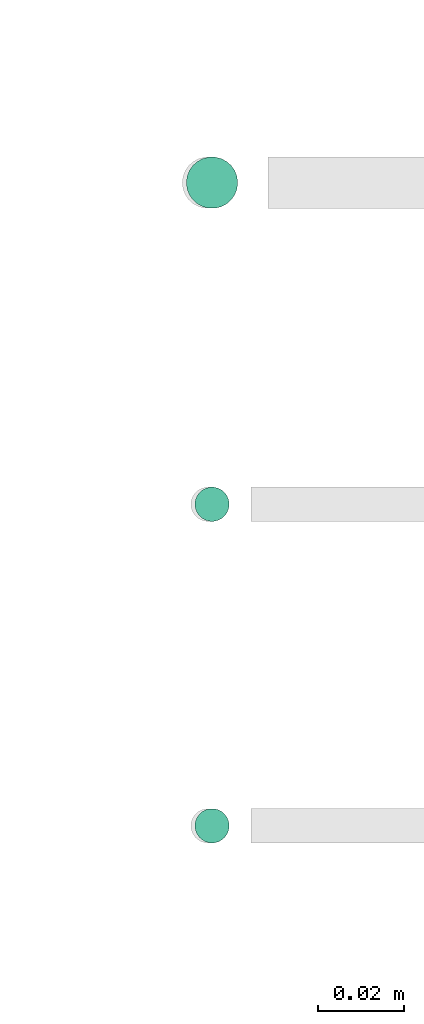
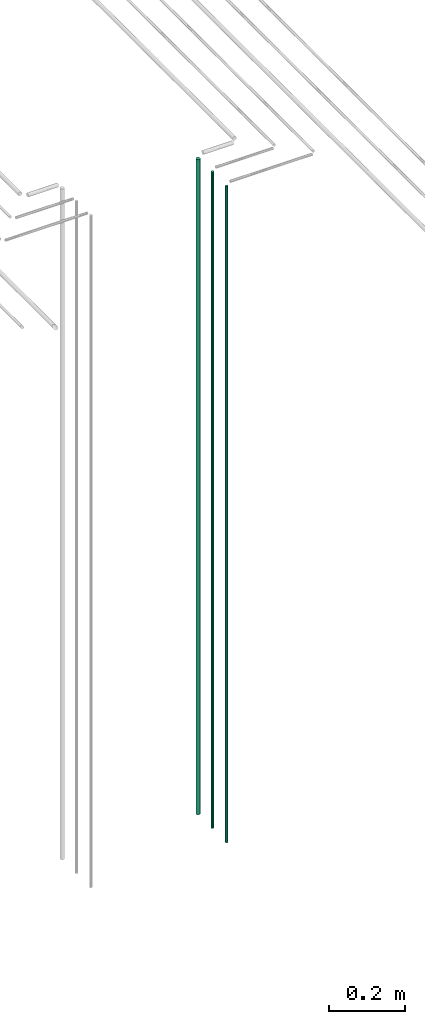
# One storey, part 48 of 331: 3 flow segments.
"""IFC2X3 building model written with IfcOpenShell, lengths in millimetres."""

import ifcopenshell
import ifcopenshell.guid

model = None  # the IFC model being written
_history = None  # IfcOwnerHistory: only IFC2X3 demands one
_inside = {}  # id of a spatial element -> (the spatial element, [elements in it])
_under = {}  # id of a project, library or spatial element -> (it, [spatial elements below it])
_declared = {}  # id of a project -> (the project, [libraries it declares])
_typed = {}  # id of a type object -> (the type object, [elements of that type])
_made_of = {}  # id of a material, layer set ... -> (it, [elements and type objects made of it])


def new_model(schema):
    """Start an empty IFC model of exactly this schema.

    Asked for "IFC4X3", IfcOpenShell would pick the latest addendum, in which some entities
    have other attributes; the version numbers below select the first issue.
    IFC2X3 requires an IfcOwnerHistory on every rooted entity: one is made here for all.
    """
    global model, _history
    if schema == "IFC4X3":
        model = ifcopenshell.file(schema_version=(4, 3, 0, 0))
    else:
        model = ifcopenshell.file(schema=schema)
    _inside.clear()
    _under.clear()
    _declared.clear()
    _typed.clear()
    _made_of.clear()
    _history = None
    if model.schema == "IFC2X3":
        org = make("IfcOrganization", Name="unknown")
        user = make(
            "IfcPersonAndOrganization",
            ThePerson=make("IfcPerson", FamilyName="unknown"),
            TheOrganization=org,
        )
        app = make(
            "IfcApplication",
            ApplicationDeveloper=org,
            Version="unknown",
            ApplicationFullName="unknown",
            ApplicationIdentifier="unknown",
        )
        _history = make(
            "IfcOwnerHistory",
            OwningUser=user,
            OwningApplication=app,
            ChangeAction="ADDED",
            CreationDate=0,
        )
    return model


def make(cls, **values):
    """One entity of the class cls with the attributes given. An attribute that is None is left unset."""
    return model.create_entity(
        cls, **{name: value for name, value in values.items() if value is not None}
    )


def entity(cls, *values):
    """Any entity or typed value of the class cls, its attributes in the order of the schema. None: left unset."""
    e = model.create_entity(cls)
    for i, value in enumerate(values):
        if value is not None:
            e[i] = value
    return e


def rooted(cls, **values):
    """An entity with a GlobalId (a new one), such as an element, a storey or a relation."""
    return make(cls, GlobalId=ifcopenshell.guid.new(), OwnerHistory=_history, **values)


def si_unit(unit_type, name, prefix=None):
    """IfcSIUnit, for example si_unit("LENGTHUNIT", "METRE", prefix="MILLI")."""
    return make("IfcSIUnit", UnitType=unit_type, Prefix=prefix, Name=name)


def converted_unit(unit_type, name, factor, base, dimensions=None, offset=None):
    """IfcConversionBasedUnit, such as the inch: factor (a typed value) times the base unit."""
    return make(
        "IfcConversionBasedUnit"
        if offset is None
        else "IfcConversionBasedUnitWithOffset",
        ConversionOffset=offset,
        Dimensions=None
        if dimensions is None
        else entity("IfcDimensionalExponents", *dimensions),
        UnitType=unit_type,
        Name=name,
        ConversionFactor=make(
            "IfcMeasureWithUnit", ValueComponent=factor, UnitComponent=base
        ),
    )


def derived_unit(unit_type, elements):
    """IfcDerivedUnit: a product of units, each with its exponent."""
    return make(
        "IfcDerivedUnit",
        Elements=[
            make("IfcDerivedUnitElement", Unit=unit, Exponent=power)
            for unit, power in elements
        ],
        UnitType=unit_type,
    )


def assignment(units):
    """IfcUnitAssignment: the units of a project."""
    return None if units is None else make("IfcUnitAssignment", Units=units)


def point(xyz):
    """IfcCartesianPoint."""
    return None if xyz is None else make("IfcCartesianPoint", Coordinates=xyz)


def direction(xyz):
    """IfcDirection."""
    return None if xyz is None else make("IfcDirection", DirectionRatios=xyz)


def frame(location, z_axis=None, x_axis=None):
    """IfcAxis2Placement3D, a coordinate frame: its origin and axes. An axis left out is left unset."""
    return make(
        "IfcAxis2Placement3D",
        Location=point(location),
        Axis=direction(z_axis),
        RefDirection=direction(x_axis),
    )


def frame_2d(location, x_axis=None):
    """IfcAxis2Placement2D, a coordinate frame in the plane: its origin and x axis."""
    return make(
        "IfcAxis2Placement2D", Location=point(location), RefDirection=direction(x_axis)
    )


def origin():
    """The frame at (0, 0, 0) with its axes left unset."""
    return frame((0.0, 0.0, 0.0))


def origin_2d_with_axis():
    """The frame at (0, 0) in the plane with the x axis (1, 0) written out."""
    return frame_2d((0.0, 0.0), x_axis=(1.0, 0.0))


def place(relative_to, where):
    """IfcLocalPlacement: puts the frame where relative to a parent placement (None: the world)."""
    return make(
        "IfcLocalPlacement", PlacementRelTo=relative_to, RelativePlacement=where
    )


def context(
    kind, dimensions, precision=None, world=None, true_north=None, identifier=None
):
    """IfcGeometricRepresentationContext, for example the 3D "Model" context."""
    return make(
        "IfcGeometricRepresentationContext",
        ContextIdentifier=identifier,
        ContextType=kind,
        CoordinateSpaceDimension=dimensions,
        Precision=precision,
        WorldCoordinateSystem=world,
        TrueNorth=true_north,
    )


def subcontext(parent, identifier, kind, view, scale=None):
    """IfcGeometricRepresentationSubContext, for example "Body" below "Model"."""
    return make(
        "IfcGeometricRepresentationSubContext",
        ContextIdentifier=identifier,
        ContextType=kind,
        ParentContext=parent,
        TargetScale=scale,
        TargetView=view,
    )


def project(units=None, contexts=None):
    """IfcProject with its units and contexts."""
    return rooted(
        "IfcProject",
        Name="project",
        RepresentationContexts=contexts,
        UnitsInContext=assignment(units),
    )


def spatial(cls, under=None, at=None, **own):
    """A site, building, storey or space (cls), placed at a placement, below another one or the project."""
    s = rooted(cls, ObjectPlacement=at, **own)
    if under is not None:
        _under.setdefault(under.id(), (under, []))[1].append(s)
    return s


def profile(cls, at=None, kind="AREA", **sizes):
    """A parametric profile (cls). Its sizes go by their IFC names, for example OverallWidth=200.0."""
    return make(cls, ProfileType=kind, Position=at, **sizes)


def circle(**sizes):
    """IfcCircleProfileDef."""
    return profile("IfcCircleProfileDef", **sizes)


def extrude(swept, where, along, depth):
    """IfcExtrudedAreaSolid: the profile swept, set in the frame where, extruded along a direction by depth."""
    return make(
        "IfcExtrudedAreaSolid",
        SweptArea=swept,
        Position=where,
        ExtrudedDirection=direction(along),
        Depth=depth,
    )


def shape(context_of_items, identifier, shape_type, items):
    """IfcShapeRepresentation: the items that make up one representation, for example the "Body"."""
    return make(
        "IfcShapeRepresentation",
        ContextOfItems=context_of_items,
        RepresentationIdentifier=identifier,
        RepresentationType=shape_type,
        Items=items,
    )


def made_of(thing, what):
    """Note that an element or type object is made of a material, layer set ...; save() writes the relation."""
    if what is not None:
        _made_of.setdefault(what.id(), (what, []))[1].append(thing)
    return thing


def type_object(cls, material=None, **own):
    """A type object (cls), such as IfcWallType, which elements share."""
    return made_of(rooted(cls, **own), material)


def element(
    cls,
    number,
    at=None,
    inside=None,
    cuts=None,
    type_object=None,
    material=None,
    context=None,
    identifier="Body",
    shape_type=None,
    held_by="IfcProductDefinitionShape",
    body=None,
    shapes=None,
    **own,
):
    """One element of the class cls, such as IfcWall. Its Tag is "e" and its number.

    at: its placement. inside: the storey or other place that contains it. cuts: it is an
    opening in that element (IfcRelVoidsElement). A single representation is given by context,
    identifier, shape_type and body (its items); several are given by shapes. held_by: the class
    of the entity that holds the representations. save() writes the other relations.
    """
    e = rooted(cls, Tag="e%d" % number, ObjectPlacement=at, **own)
    if body is not None:
        shapes = [shape(context, identifier, shape_type, body)]
    if shapes is not None:
        e.Representation = make(held_by, Representations=shapes)
    if inside is not None:
        _inside.setdefault(inside.id(), (inside, []))[1].append(e)
    if cuts is not None:
        rooted(
            "IfcRelVoidsElement", RelatingBuildingElement=cuts, RelatedOpeningElement=e
        )
    if type_object is not None:
        _typed.setdefault(type_object.id(), (type_object, []))[1].append(e)
    return made_of(e, material)


def aggregate(whole, parts):
    """IfcRelAggregates: a whole, such as a stair, and the parts it consists of."""
    return rooted("IfcRelAggregates", RelatingObject=whole, RelatedObjects=parts)


def save(model, path):
    """Write the relations noted so far, then the file.

    IfcRelAggregates (storeys below a building ...), IfcRelContainedInSpatialStructure (elements
    in a storey), IfcRelDefinesByType, IfcRelAssociatesMaterial and IfcRelDeclares: one each for
    every whole, place, type object, material and project.
    """
    for whole, parts in _under.values():
        aggregate(whole, parts)
    for where, things in _inside.values():
        rooted(
            "IfcRelContainedInSpatialStructure",
            RelatedElements=things,
            RelatingStructure=where,
        )
    for kind, things in _typed.values():
        rooted("IfcRelDefinesByType", RelatedObjects=things, RelatingType=kind)
    for what, things in _made_of.values():
        rooted("IfcRelAssociatesMaterial", RelatedObjects=things, RelatingMaterial=what)
    for by, libraries in _declared.values():
        rooted("IfcRelDeclares", RelatingContext=by, RelatedDefinitions=libraries)
    model.write(path)


model = new_model("IFC2X3")

# Units and contexts
model_context = context("Model", 3, precision=0.01, world=origin(), true_north=direction((6.12303176911189e-17, 1.0)))
body_context = subcontext(model_context, "Body", "Model", "MODEL_VIEW")
ifc_project = project(units=[si_unit("LENGTHUNIT", "METRE", prefix="MILLI"), si_unit("AREAUNIT", "SQUARE_METRE"), si_unit("VOLUMEUNIT", "CUBIC_METRE"), converted_unit("PLANEANGLEUNIT", "DEGREE", entity("IfcRatioMeasure", 0.0174532925199433), si_unit("PLANEANGLEUNIT", "RADIAN"), dimensions=[0, 0, 0, 0, 0, 0, 0]), si_unit("MASSUNIT", "GRAM", prefix="KILO"), derived_unit("MASSDENSITYUNIT", [(si_unit("MASSUNIT", "GRAM", prefix="KILO"), 1), (si_unit("LENGTHUNIT", "METRE"), -3)]), derived_unit("MOMENTOFINERTIAUNIT", [(si_unit("LENGTHUNIT", "METRE"), 4)]), si_unit("TIMEUNIT", "SECOND"), si_unit("FREQUENCYUNIT", "HERTZ"), si_unit("THERMODYNAMICTEMPERATUREUNIT", "DEGREE_CELSIUS"), derived_unit("THERMALTRANSMITTANCEUNIT", [(si_unit("MASSUNIT", "GRAM", prefix="KILO"), 1), (si_unit("THERMODYNAMICTEMPERATUREUNIT", "KELVIN"), -1), (si_unit("TIMEUNIT", "SECOND"), -3)]), derived_unit("VOLUMETRICFLOWRATEUNIT", [(si_unit("LENGTHUNIT", "METRE"), 3), (si_unit("TIMEUNIT", "SECOND"), -1)]), derived_unit("MASSFLOWRATEUNIT", [(si_unit("MASSUNIT", "GRAM", prefix="KILO"), 1), (si_unit("TIMEUNIT", "SECOND"), -1)]), derived_unit("ROTATIONALFREQUENCYUNIT", [(si_unit("TIMEUNIT", "SECOND"), -1)]), si_unit("ELECTRICCURRENTUNIT", "AMPERE"), si_unit("ELECTRICVOLTAGEUNIT", "VOLT"), si_unit("POWERUNIT", "WATT"), si_unit("FORCEUNIT", "NEWTON", prefix="KILO"), si_unit("ILLUMINANCEUNIT", "LUX"), si_unit("LUMINOUSFLUXUNIT", "LUMEN"), si_unit("LUMINOUSINTENSITYUNIT", "CANDELA"), derived_unit("USERDEFINED", [(si_unit("MASSUNIT", "GRAM", prefix="KILO"), -1), (si_unit("LENGTHUNIT", "METRE"), -2), (si_unit("TIMEUNIT", "SECOND"), 3), (si_unit("LUMINOUSFLUXUNIT", "LUMEN"), 1)]), derived_unit("LINEARVELOCITYUNIT", [(si_unit("LENGTHUNIT", "METRE"), 1), (si_unit("TIMEUNIT", "SECOND"), -1)]), si_unit("PRESSUREUNIT", "PASCAL"), derived_unit("USERDEFINED", [(si_unit("LENGTHUNIT", "METRE"), -2), (si_unit("MASSUNIT", "GRAM", prefix="KILO"), 1), (si_unit("TIMEUNIT", "SECOND"), -2)]), derived_unit("LINEARFORCEUNIT", [(si_unit("MASSUNIT", "GRAM", prefix="KILO"), 1), (si_unit("LENGTHUNIT", "METRE"), 1), (si_unit("TIMEUNIT", "SECOND"), -2), (si_unit("LENGTHUNIT", "METRE"), -1)]), derived_unit("PLANARFORCEUNIT", [(si_unit("MASSUNIT", "GRAM", prefix="KILO"), 1), (si_unit("LENGTHUNIT", "METRE"), 1), (si_unit("TIMEUNIT", "SECOND"), -2), (si_unit("LENGTHUNIT", "METRE"), -2)])], contexts=[model_context])

# Site, building, storey
site_placement = place(None, frame((0.0, -0.00077364408347762, 0.0)))
site = spatial("IfcSite", under=ifc_project, at=site_placement, CompositionType="ELEMENT")
building_placement = place(site_placement, origin())
building = spatial("IfcBuilding", under=site, at=building_placement, CompositionType="ELEMENT")
storey_placement = place(building_placement, origin())
storey = spatial("IfcBuildingStorey", under=building, at=storey_placement, CompositionType="ELEMENT", Elevation=0.0)

# Flow segments
pipe_segment_type = type_object("IfcPipeSegmentType", PredefinedType="NOTDEFINED")
flow_segment_placement = place(storey_placement, frame((44369.1288658284, 3883.8934948435, 12990.0)))
element("IfcFlowSegment", 1, at=flow_segment_placement, inside=storey, type_object=pipe_segment_type, context=body_context, shape_type="SweptSolid", body=[
    extrude(circle(Radius=6.0, at=origin_2d_with_axis()), frame((7.59527223591454, 7.59527223591616, 0.0)), (0.0, 0.0, 1.0), 2096.0),
])
for number, where in (
    (2, (44371.1288658284, 3735.89349484333, 12990.0)),
    (3, (44371.1288658284, 3810.89349484378, 12990.0)),
):
    element("IfcFlowSegment", number, at=place(storey_placement, frame(where)), inside=storey, type_object=pipe_segment_type, context=body_context, shape_type="SweptSolid", body=[
        extrude(circle(Radius=4.0, at=origin_2d_with_axis()), frame((5.59527223591499, 5.59527223591607, 0.0)), (0.0, 0.0, 1.0), 2100.0),
    ])

save(model, "model.ifc")
